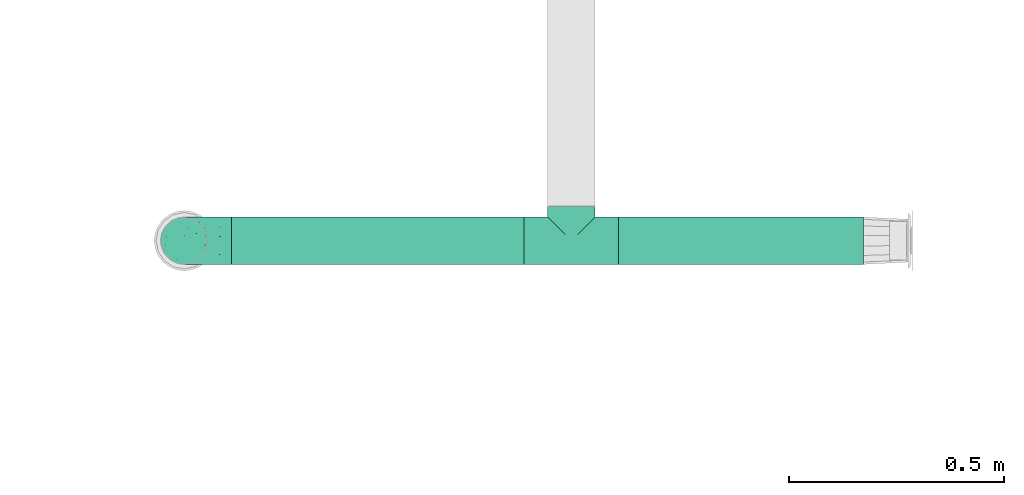
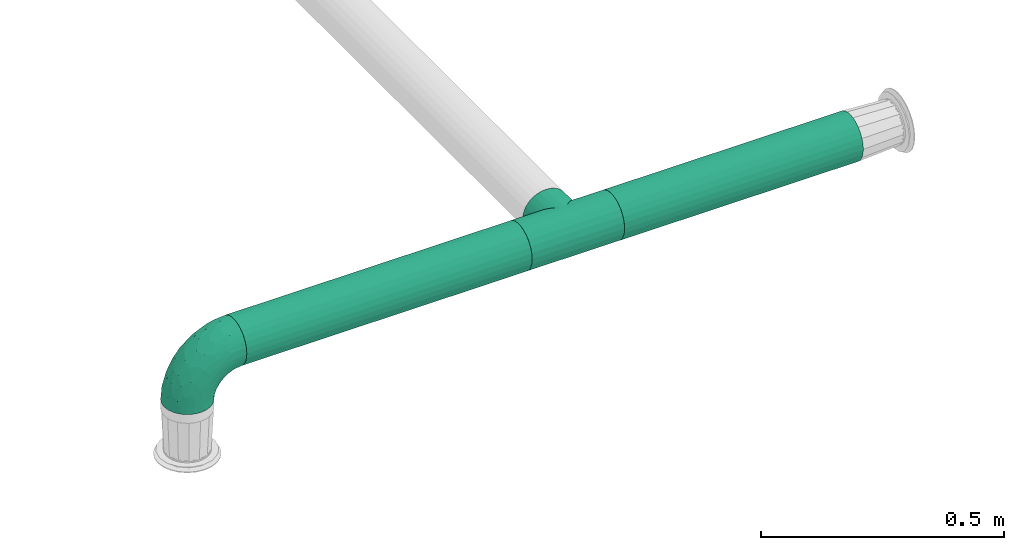
# One storey, part 101 of 123: 2 flow fittings, 2 flow segments.
"""IFC2X3 building model written with IfcOpenShell, lengths in millimetres."""

from ifc_helpers import new_model, entity, si_unit, converted_unit, derived_unit, direction, frame, origin_with_axes, origin_2d_with_axis, place, context, subcontext, project, spatial, hollow_circle, extrude, open_shell, surface_model, source, transform, mapped, material, layer, layer_set, layer_usage, type_object, element, save


model = new_model("IFC2X3")

# Units and contexts
model_context = context("Model", 3, precision=1e-05, world=origin_with_axes(), true_north=direction((0.0, 1.0)))
body_context = subcontext(model_context, "Body", "Model", "MODEL_VIEW")
ifc_project = project(units=[si_unit("AREAUNIT", "SQUARE_METRE"), si_unit("VOLUMEUNIT", "CUBIC_METRE", prefix="DECI"), si_unit("TIMEUNIT", "SECOND"), si_unit("THERMODYNAMICTEMPERATUREUNIT", "DEGREE_CELSIUS"), si_unit("PRESSUREUNIT", "PASCAL"), si_unit("MASSUNIT", "GRAM", prefix="KILO"), si_unit("LENGTHUNIT", "METRE", prefix="MILLI"), si_unit("POWERUNIT", "WATT"), si_unit("ELECTRICCURRENTUNIT", "AMPERE"), si_unit("ELECTRICVOLTAGEUNIT", "VOLT"), derived_unit("VOLUMETRICFLOWRATEUNIT", [(si_unit("VOLUMEUNIT", "CUBIC_METRE", prefix="DECI"), 1), (si_unit("TIMEUNIT", "SECOND"), -1)]), derived_unit("LINEARVELOCITYUNIT", [(si_unit("LENGTHUNIT", "METRE"), 1), (si_unit("TIMEUNIT", "SECOND"), -1)]), derived_unit("MASSDENSITYUNIT", [(si_unit("MASSUNIT", "GRAM", prefix="KILO"), 1), (si_unit("VOLUMEUNIT", "CUBIC_METRE"), -1)]), converted_unit("PLANEANGLEUNIT", "DEGREE", entity("IfcRatioMeasure", 0.01745), si_unit("PLANEANGLEUNIT", "RADIAN"), dimensions=[0, 0, 0, 0, 0, 0, 0])], contexts=[model_context])

# Site, building, storey
site_placement = place(None, origin_with_axes())
site = spatial("IfcSite", under=ifc_project, at=site_placement, CompositionType="ELEMENT")
building_placement = place(site_placement, origin_with_axes())
building = spatial("IfcBuilding", under=site, at=building_placement, Name="mc-building", CompositionType="ELEMENT")
storey_placement = place(building_placement, origin_with_axes())
storey = spatial("IfcBuildingStorey", under=building, at=storey_placement, Name="1. Korrus", CompositionType="ELEMENT", Elevation=0.0)

# Flow fitting
duct_fitting_type_1 = type_object("IfcDuctFittingType", PredefinedType="JUNCTION")
shared_shape_1 = source(origin_with_axes(), body_context, "Body", "SurfaceModel", [
    surface_model("IfcShellBasedSurfaceModel", [(0.0, -80.0, -55.0), (14.23505, -80.0, -53.12592), (-14.23505, -80.0, -53.12592), (-53.12592, -80.0, 14.23505), (-27.5, -80.0, -47.63139), (-47.63139, -80.0, -27.5), (-38.89087, -80.0, -38.89087), (55.0, -80.0, 0.0), (53.12592, -80.0, 14.23505), (38.89087, -80.0, -38.89087), (27.5, -80.0, -47.63139), (53.12592, -80.0, -14.23505), (47.63139, -80.0, -27.5), (-53.12592, -80.0, -14.23505), (-47.63139, -80.0, 27.5), (-38.89087, -80.0, 38.89087), (14.23505, -80.0, 53.12592), (-27.5, -80.0, 47.63139), (-14.23505, -80.0, 53.12592), (47.63139, -80.0, 27.5), (38.89087, -80.0, 38.89087), (27.5, -80.0, 47.63139), (0.0, -80.0, 55.0), (-55.0, -80.0, 0.0), (0.0, 0.0, 55.0), (-7.4066, -7.4066, 54.49901), (-14.74521, -14.74521, 52.98659), (-21.93978, -21.93978, 50.43457), (-28.89905, -28.89905, 46.79578), (-35.50357, -35.50357, 42.00591), (-41.58668, -41.58668, 35.99373), (-46.92319, -46.92319, 28.69171), (-51.19777, -51.19777, 20.0945), (-50.37866, -80.0, 20.86752), (-54.01174, -54.01174, 10.37938), (-55.0, -55.0, 0.0), (-54.06296, -80.0, 7.11752), (-54.01174, -54.01174, -10.37938), (-51.19777, -51.19777, -20.0945), (-54.06296, -80.0, -7.11752), (-46.92319, -46.92319, -28.69171), (-41.58668, -41.58668, -35.99373), (-50.37866, -80.0, -20.86752), (-35.50357, -35.50357, -42.00591), (-21.93978, -21.93978, -50.43457), (-14.74521, -14.74521, -52.98659), (-7.4066, -7.4066, -54.49901), (0.0, 0.0, -55.0), (-28.89905, -28.89905, -46.79578), (7.4066, -7.4066, -54.49901), (14.74521, -14.74521, -52.98659), (21.93978, -21.93978, -50.43457), (28.89905, -28.89905, -46.79578), (35.50357, -35.50357, -42.00591), (41.58668, -41.58668, -35.99373), (46.92319, -46.92319, -28.69171), (51.19777, -51.19777, -20.0945), (50.37866, -80.0, -20.86752), (54.01174, -54.01174, -10.37938), (55.0, -55.0, 0.0), (54.06296, -80.0, -7.11752), (54.01174, -54.01174, 10.37938), (51.19777, -51.19777, 20.0945), (54.06296, -80.0, 7.11752), (46.92319, -46.92319, 28.69171), (41.58668, -41.58668, 35.99373), (50.37866, -80.0, 20.86752), (35.50357, -35.50357, 42.00591), (21.93978, -21.93978, 50.43457), (14.74521, -14.74521, 52.98659), (7.4066, -7.4066, 54.49901), (28.89905, -28.89905, 46.79578), (-110.0, 0.0, -55.0), (-110.0, -14.23505, -53.12592), (-110.0, 14.23505, -53.12592), (-110.0, 53.12592, 14.23505), (-110.0, 27.5, -47.63139), (-110.0, 47.63139, -27.5), (-110.0, 38.89087, -38.89087), (-110.0, -55.0, 0.0), (-110.0, -53.12592, 14.23505), (-110.0, -38.89087, -38.89087), (-110.0, -27.5, -47.63139), (-110.0, -53.12592, -14.23505), (-110.0, -47.63139, -27.5), (-110.0, 53.12592, -14.23505), (-110.0, 47.63139, 27.5), (-110.0, 38.89087, 38.89087), (-110.0, -14.23505, 53.12592), (-110.0, 27.5, 47.63139), (-110.0, 14.23505, 53.12592), (-110.0, -47.63139, 27.5), (-110.0, -38.89087, 38.89087), (-110.0, -27.5, 47.63139), (-110.0, 0.0, 55.0), (-110.0, 55.0, 0.0), (110.0, 55.0, 0.0), (110.0, 0.0, -55.0), (110.0, 14.23505, -53.12592), (110.0, 27.5, -47.63139), (110.0, 38.89087, -38.89087), (110.0, 47.63139, -27.5), (110.0, -38.89087, -38.89087), (110.0, -53.12592, 14.23505), (110.0, -27.5, -47.63139), (110.0, -14.23505, -53.12592), (110.0, -47.63139, -27.5), (110.0, -53.12592, -14.23505), (110.0, -55.0, 0.0), (110.0, 53.12592, -14.23505), (110.0, 53.12592, 14.23505), (110.0, 47.63139, 27.5), (110.0, 38.89087, 38.89087), (110.0, 0.0, 55.0), (110.0, 27.5, 47.63139), (110.0, 14.23505, 53.12592), (110.0, -47.63139, 27.5), (110.0, -38.89087, 38.89087), (110.0, -27.5, 47.63139), (110.0, -14.23505, 53.12592)], [open_shell([[[0, 1, 2]], [[2, 3, 4]], [[5, 6, 3]], [[6, 4, 3]], [[2, 7, 8]], [[9, 7, 10]], [[1, 10, 7]], [[11, 7, 12]], [[9, 12, 7]], [[7, 2, 1]], [[5, 3, 13]], [[2, 14, 3]], [[2, 15, 14]], [[2, 16, 17]], [[17, 15, 2]], [[16, 18, 17]], [[2, 8, 19]], [[2, 19, 20]], [[2, 20, 21]], [[16, 2, 21]], [[16, 22, 18]], [[23, 13, 3]], [[24, 25, 22]], [[26, 27, 18]], [[25, 26, 18]], [[22, 25, 18]], [[17, 28, 29]], [[17, 18, 27]], [[17, 29, 15]], [[28, 17, 27]], [[30, 31, 14]], [[32, 3, 33]], [[32, 34, 3]], [[35, 36, 34]], [[31, 32, 14]], [[15, 30, 14]], [[34, 36, 3]], [[33, 14, 32]], [[36, 35, 23]], [[30, 15, 29]], [[37, 38, 13]], [[37, 13, 39]], [[40, 41, 5]], [[38, 5, 42]], [[38, 40, 5]], [[37, 39, 35]], [[35, 39, 23]], [[13, 38, 42]], [[41, 6, 5]], [[41, 43, 6]], [[44, 45, 2]], [[46, 47, 0]], [[45, 46, 2]], [[43, 48, 4]], [[44, 4, 48]], [[44, 2, 4]], [[46, 0, 2]], [[43, 4, 6]], [[47, 49, 0]], [[50, 51, 1]], [[49, 50, 1]], [[0, 49, 1]], [[10, 52, 53]], [[10, 1, 51]], [[10, 53, 9]], [[52, 10, 51]], [[54, 55, 12]], [[56, 11, 57]], [[56, 58, 11]], [[59, 60, 58]], [[55, 56, 12]], [[9, 54, 12]], [[58, 60, 11]], [[57, 12, 56]], [[60, 59, 7]], [[54, 9, 53]], [[61, 62, 8]], [[61, 8, 63]], [[64, 65, 19]], [[62, 19, 66]], [[62, 64, 19]], [[61, 63, 59]], [[7, 59, 63]], [[62, 66, 8]], [[65, 20, 19]], [[65, 67, 20]], [[68, 69, 16]], [[70, 24, 22]], [[69, 70, 16]], [[67, 71, 21]], [[68, 21, 71]], [[68, 16, 21]], [[70, 22, 16]], [[67, 21, 20]], [[72, 73, 74]], [[74, 75, 76]], [[77, 78, 75]], [[76, 75, 78]], [[74, 79, 80]], [[81, 79, 82]], [[73, 82, 79]], [[83, 79, 84]], [[81, 84, 79]], [[79, 74, 73]], [[77, 75, 85]], [[74, 86, 75]], [[74, 87, 86]], [[74, 88, 89]], [[89, 87, 74]], [[88, 90, 89]], [[74, 91, 92]], [[91, 74, 80]], [[92, 93, 74]], [[74, 93, 88]], [[88, 94, 90]], [[95, 85, 75]], [[96, 97, 98]], [[99, 96, 98]], [[96, 100, 101]], [[100, 96, 99]], [[102, 97, 103]], [[97, 102, 104]], [[104, 105, 97]], [[102, 103, 106]], [[106, 103, 107]], [[108, 107, 103]], [[109, 96, 101]], [[110, 111, 97]], [[97, 111, 112]], [[113, 97, 114]], [[97, 112, 114]], [[113, 114, 115]], [[116, 103, 97]], [[117, 116, 97]], [[118, 117, 97]], [[119, 118, 97]], [[119, 97, 113]], [[96, 110, 97]], [[24, 113, 115]], [[89, 115, 114]], [[94, 24, 90]], [[90, 24, 115]], [[115, 89, 90]], [[114, 87, 89]], [[86, 112, 111]], [[75, 111, 110]], [[95, 110, 96]], [[87, 112, 86]], [[86, 111, 75]], [[110, 95, 75]], [[112, 87, 114]], [[85, 96, 109]], [[77, 109, 101]], [[95, 96, 85]], [[85, 109, 77]], [[101, 78, 77]], [[101, 100, 78]], [[76, 100, 99]], [[74, 99, 98]], [[47, 98, 97]], [[76, 99, 74]], [[47, 72, 74]], [[98, 47, 74]], [[100, 76, 78]], [[47, 46, 72]], [[45, 44, 73]], [[46, 45, 73]], [[72, 46, 73]], [[82, 48, 43]], [[82, 73, 44]], [[82, 43, 81]], [[48, 82, 44]], [[41, 40, 84]], [[38, 37, 83]], [[40, 38, 84]], [[81, 41, 84]], [[37, 79, 83]], [[83, 84, 38]], [[79, 37, 35]], [[41, 81, 43]], [[49, 97, 105]], [[105, 104, 51]], [[53, 104, 102]], [[53, 52, 104]], [[49, 47, 97]], [[51, 50, 105]], [[52, 51, 104]], [[49, 105, 50]], [[54, 102, 106]], [[56, 106, 107]], [[58, 107, 108]], [[55, 54, 106]], [[58, 56, 107]], [[59, 58, 108]], [[55, 106, 56]], [[102, 54, 53]], [[34, 32, 80]], [[31, 30, 91]], [[32, 31, 91]], [[35, 34, 79]], [[80, 79, 34]], [[32, 91, 80]], [[30, 92, 91]], [[30, 29, 92]], [[27, 26, 88]], [[25, 24, 94]], [[26, 25, 88]], [[29, 28, 93]], [[27, 93, 28]], [[27, 88, 93]], [[25, 94, 88]], [[29, 93, 92]], [[61, 108, 103]], [[62, 103, 116]], [[65, 116, 117]], [[61, 59, 108]], [[64, 62, 116]], [[65, 64, 116]], [[61, 103, 62]], [[117, 67, 65]], [[71, 67, 118]], [[118, 67, 117]], [[68, 118, 119]], [[70, 119, 113]], [[68, 71, 118]], [[70, 69, 119]], [[24, 70, 113]], [[68, 119, 69]]])]),
])
flow_fitting_1_placement = place(storey_placement, frame((33028.54629, 9877.62755, 2435.0), z_axis=(0.0, 0.0, 1.0), x_axis=(-1.0, 0.0, 0.0)))
element("IfcFlowFitting", 1, at=flow_fitting_1_placement, inside=storey, type_object=duct_fitting_type_1, context=body_context, shape_type="MappedRepresentation", body=[
    mapped(shared_shape_1, transform((0.0, 0.0, 0.0), scale=1.0)),
])

# Flow segment
ifc_material = material(Name="FZ1")
ifc_layer = layer(ifc_material, 0.0)
ifc_layer_set = layer_set([ifc_layer], Name="FZ1")
ifc_layer_usage = layer_usage(ifc_layer_set, "AXIS1", "POSITIVE", 0.0)
duct_segment_type = type_object("IfcDuctSegmentType", PredefinedType="RIGIDSEGMENT")
shared_shape_2 = source(origin_with_axes(), body_context, "Body", "SweptSolid", [
    extrude(hollow_circle(Radius=55.0, WallThickness=2.0, at=origin_2d_with_axis()), frame((0.0, 0.0, 0.0), z_axis=(1.0, 0.0, 0.0), x_axis=(0.0, 1.0, 0.0)), (0.0, 0.0, 1.0), 568.2),
])
flow_segment_1_placement = place(storey_placement, frame((33138.54629, 9877.62755, 2435.0), z_axis=(0.0, 0.0, 1.0), x_axis=(1.0, 0.0, 0.0)))
element("IfcFlowSegment", 2, at=flow_segment_1_placement, inside=storey, type_object=duct_segment_type, material=ifc_layer_usage, context=body_context, shape_type="MappedRepresentation", body=[
    mapped(shared_shape_2, transform((0.0, 0.0, 0.0), scale=1.0)),
])

# Flow fitting
duct_fitting_type_2 = type_object("IfcDuctFittingType", Name="BU", PredefinedType="BEND")
shared_shape_3 = source(origin_with_axes(), body_context, "Body", "SurfaceModel", [
    surface_model("IfcShellBasedSurfaceModel", [(-110.0, 0.0, -55.0), (-110.0, -14.23505, -53.12592), (-110.0, 14.23505, -53.12592), (-110.0, 53.12592, 14.23505), (-110.0, 27.5, -47.63139), (-110.0, 38.89087, -38.89087), (-110.0, -55.0, 0.0), (-110.0, -53.12592, 14.23505), (-110.0, -38.89087, -38.89087), (-110.0, -27.5, -47.63139), (-110.0, -53.12592, -14.23505), (-110.0, -47.63139, -27.5), (-110.0, -14.23505, 53.12592), (-110.0, 14.23505, 53.12592), (-110.0, 27.5, 47.63139), (-110.0, -47.63139, 27.5), (-110.0, -38.89087, 38.89087), (-110.0, -27.5, 47.63139), (-110.0, 0.0, 55.0), (-110.0, 55.0, 0.0), (-110.0, 53.12592, -14.23505), (-110.0, 47.63139, -27.5), (-110.0, 47.63139, 27.5), (-110.0, 38.89087, 38.89087), (-14.23505, 110.0, -53.12592), (-55.0, 110.0, 0.0), (0.0, 110.0, -55.0), (-27.5, 110.0, -47.63139), (-38.89087, 110.0, -38.89087), (-47.63139, 110.0, -27.5), (38.89087, 110.0, -38.89087), (53.12592, 110.0, 14.23505), (27.5, 110.0, -47.63139), (14.23505, 110.0, -53.12592), (47.63139, 110.0, -27.5), (53.12592, 110.0, -14.23505), (55.0, 110.0, 0.0), (-53.12592, 110.0, -14.23505), (-53.12592, 110.0, 14.23505), (-47.63139, 110.0, 27.5), (-38.89087, 110.0, 38.89087), (-27.5, 110.0, 47.63139), (0.0, 110.0, 55.0), (-14.23505, 110.0, 53.12592), (38.89087, 110.0, 38.89087), (47.63139, 110.0, 27.5), (27.5, 110.0, 47.63139), (14.23505, 110.0, 53.12592), (-64.21732, 48.68956, 43.63444), (-76.6405, 38.18013, 45.55988), (-60.44912, 32.56953, 51.94617), (-76.00813, 5.38378, 55.0), (-90.15553, 11.94394, 54.09138), (-78.5998, 26.77405, 50.81338), (-70.18771, 18.55163, 54.03432), (-75.55424, 54.2118, 32.41257), (-93.27622, 45.77614, 33.48188), (-96.12334, 22.13664, 50.81337), (-21.00813, 45.34362, 55.0), (-18.36258, 70.48427, 54.04484), (-32.04182, 59.64019, 52.24446), (-63.88653, 74.77858, 17.99134), (-74.66383, 63.08407, 19.92123), (-63.60674, 66.07878, 29.97482), (-99.597, 52.72185, 18.52927), (-93.11138, 56.59448, 10.50359), (-98.21577, 57.34403, 0.0), (-53.42855, 92.60092, 21.04759), (-88.54852, 54.8376, 21.04759), (-11.86161, 90.23965, 54.10313), (-5.38378, 76.00813, 55.0), (-57.34403, 98.21577, 0.0), (-56.64619, 93.12774, 10.22088), (-45.34362, 21.00813, 55.0), (-44.60838, 44.60838, 52.13415), (-92.68484, 35.46673, 43.63443), (-22.25266, 95.40765, 50.81337), (-35.97783, 90.61597, 43.63443), (-43.70931, 69.58671, 44.47149), (-27.23711, 77.39884, 50.81337), (-57.2828, 79.3123, 24.9774), (-58.67786, 84.31125, 16.04456), (-82.93277, 60.36161, 12.91784), (-49.88337, 54.51816, 47.224), (-74.57753, 66.83759, 9.55742), (-45.35812, 94.97281, 33.48188), (-59.18663, 88.95241, 0.0), (-51.517, 78.6292, 33.48188), (-65.14788, 80.03077, 0.0), (-56.45322, 62.06476, 39.63545), (-88.95241, 59.18663, 0.0), (-71.10913, 71.10913, 0.0), (-80.03077, 65.14788, 0.0), (-94.9309, 45.36788, -33.48188), (-93.11358, 56.60141, -10.46614), (-99.64997, 52.79499, -18.30015), (-90.20425, 36.08686, -43.63443), (-79.99933, 46.56772, -37.92748), (-76.00813, 5.38378, -55.0), (-72.75364, 19.68651, -53.60527), (-45.34362, 21.00813, -55.0), (-21.91957, 65.12078, -53.85897), (-5.38378, 76.00813, -55.0), (-21.00813, 45.34362, -55.0), (-35.41876, 92.89265, -43.63443), (-91.10309, 11.02766, -54.21832), (-45.77614, 93.27622, -33.48188), (-90.50474, 23.21022, -50.81337), (-70.92854, 33.31794, -49.51754), (-78.52933, 63.35627, -11.73997), (-24.91508, 84.05606, -50.81337), (-88.78941, 54.74452, -21.04759), (-69.59921, 57.34866, -33.48187), (-73.36422, 62.46673, -22.94182), (-63.49062, 67.59111, -28.46929), (-56.59448, 93.11138, -10.50359), (-54.8376, 88.54852, -21.04759), (-54.10679, 75.85581, -32.31867), (-57.75956, 31.09612, -52.80882), (-52.72185, 99.597, -18.52927), (-12.62913, 89.46304, -53.99097), (-34.46825, 66.46123, -50.04329), (-43.9837, 43.9837, -52.42279), (-65.78527, 72.58348, -17.68796), (-70.34468, 43.65295, -44.21951), (-57.47001, 51.99467, -44.91465), (-60.72547, 82.29174, -12.88567), (-42.34915, 74.24548, -43.63444), (-57.25194, 63.5016, -38.08211), (-80.95344, 53.56991, -29.32027), (-52.32891, 4.55257, -54.0482), (32.52942, 47.13398, -30.48571), (14.88266, 20.92917, -33.7947), (14.95561, 36.05775, -42.26543), (30.24048, 70.09027, -41.7461), (19.3559, 65.35825, -48.00507), (-70.35075, -46.44478, -19.5952), (-47.13398, -32.52942, -30.48571), (-28.49299, -30.5778, -16.4009), (-4.55257, 52.32891, -54.0482), (-22.4954, 22.4954, -53.25347), (-75.47368, -11.22546, -52.60718), (-81.32209, -51.5606, -9.98467), (-80.81763, -41.84862, -32.14655), (-70.09027, -30.24048, -41.7461), (-36.05774, -14.95561, -42.26543), (-9.15831, -10.852, -27.8997), (-65.35825, -19.3559, -48.00507), (11.22546, 75.47368, -52.60718), (3.94376, 43.9333, -50.53315), (-13.39742, 13.39743, -48.13058), (-43.9333, -3.94376, -50.53315), (49.37776, 67.29486, 0.0), (41.8609, 47.82256, -9.92641), (50.20582, 74.51695, -9.9731), (18.93131, 11.7156, -17.56239), (-27.5, -32.89419, 0.0), (-1.23348, -12.25375, -12.18106), (41.84862, 80.81763, -32.14655), (35.70604, 41.31408, -20.38235), (46.44478, 70.35075, -19.5952), (32.89419, 27.5, 0.0), (6.67262, -6.67262, 0.0), (-67.29486, -49.37776, 0.0), (-50.36265, -42.95545, -9.51562), (-5.47251, 5.47251, -39.92906), (-70.35075, -46.44478, 19.5952), (-74.51695, -50.20582, 9.9731), (-41.31407, -35.70604, 20.38235), (-47.13398, -32.52942, 30.48571), (-80.81763, -41.84862, 32.14655), (-4.55257, 52.32891, 54.0482), (11.22546, 75.47368, 52.60718), (-43.9333, -3.94376, 50.53315), (-65.35825, -19.3559, 48.00507), (-36.05774, -14.95561, 42.26543), (-70.09027, -30.24048, 41.7461), (-11.7156, -18.93131, 17.56239), (30.5778, 28.49299, 16.4009), (12.25375, 1.23348, 12.18106), (51.5606, 81.32209, 9.98467), (42.95545, 50.36265, 9.51562), (-75.47368, -11.22546, 52.60718), (-52.32891, 4.55257, 54.0482), (3.94376, 43.9333, 50.53315), (-22.4954, 22.4954, 53.25347), (-13.39742, 13.39743, 48.13058), (10.852, 9.15831, 27.8997), (-20.92916, -14.88266, 33.79469), (-47.82256, -41.8609, 9.92641), (32.52942, 47.13398, 30.48571), (46.44478, 70.35075, 19.5952), (41.84862, 80.81763, 32.14655), (30.24048, 70.09027, 41.7461), (19.3559, 65.35825, 48.00507), (14.95561, 36.05775, 42.26543), (-5.47251, 5.47251, 39.92906)], [open_shell([[[0, 1, 2]], [[2, 3, 4]], [[4, 3, 5]], [[2, 6, 7]], [[8, 6, 9]], [[1, 9, 6]], [[10, 6, 11]], [[8, 11, 6]], [[6, 2, 1]], [[12, 13, 14]], [[15, 2, 7]], [[16, 17, 2]], [[2, 17, 12]], [[12, 18, 13]], [[19, 20, 3]], [[5, 3, 21]], [[20, 21, 3]], [[22, 3, 2]], [[23, 22, 2]], [[12, 14, 2]], [[2, 14, 23]], [[15, 16, 2]], [[24, 25, 26]], [[27, 25, 24]], [[25, 28, 29]], [[28, 25, 27]], [[30, 26, 31]], [[26, 30, 32]], [[32, 33, 26]], [[34, 31, 35]], [[31, 34, 30]], [[35, 31, 36]], [[29, 37, 25]], [[38, 39, 26]], [[39, 40, 26]], [[41, 42, 40]], [[42, 26, 40]], [[42, 41, 43]], [[26, 44, 45]], [[31, 26, 45]], [[26, 46, 44]], [[47, 46, 26]], [[42, 47, 26]], [[25, 38, 26]], [[48, 49, 50]], [[18, 51, 52]], [[53, 54, 50]], [[55, 56, 49]], [[56, 22, 23]], [[13, 57, 14]], [[58, 59, 60]], [[61, 62, 63]], [[3, 64, 65]], [[53, 52, 54]], [[3, 65, 66]], [[67, 39, 38]], [[56, 68, 64]], [[65, 64, 68]], [[69, 59, 70]], [[38, 71, 72]], [[73, 58, 74]], [[75, 49, 56]], [[76, 69, 43]], [[53, 57, 52]], [[77, 78, 79]], [[41, 76, 43]], [[43, 69, 42]], [[55, 68, 56]], [[23, 14, 75]], [[76, 77, 79]], [[80, 67, 81]], [[62, 82, 68]], [[60, 78, 83]], [[62, 84, 82]], [[85, 77, 40]], [[81, 67, 72]], [[86, 72, 71]], [[87, 85, 67]], [[61, 81, 88]], [[77, 41, 40]], [[78, 77, 87]], [[23, 75, 56]], [[83, 89, 48]], [[85, 40, 39]], [[62, 68, 55]], [[89, 87, 63]], [[83, 48, 50]], [[57, 75, 14]], [[49, 75, 53]], [[67, 85, 39]], [[87, 77, 85]], [[63, 62, 55]], [[89, 55, 48]], [[80, 63, 87]], [[66, 65, 90]], [[66, 19, 3]], [[84, 91, 92]], [[92, 90, 82]], [[65, 82, 90]], [[61, 84, 62]], [[92, 82, 84]], [[68, 82, 65]], [[3, 22, 64]], [[56, 64, 22]], [[38, 25, 71]], [[81, 72, 86]], [[38, 72, 67]], [[91, 61, 88]], [[80, 81, 61]], [[63, 80, 61]], [[67, 80, 87]], [[77, 76, 41]], [[79, 59, 69]], [[79, 69, 76]], [[42, 69, 70]], [[60, 59, 79]], [[58, 70, 59]], [[78, 60, 79]], [[58, 60, 74]], [[52, 57, 13]], [[75, 57, 53]], [[18, 52, 13]], [[52, 51, 54]], [[51, 73, 54]], [[50, 73, 74]], [[73, 50, 54]], [[50, 74, 83]], [[60, 83, 74]], [[89, 83, 78]], [[87, 89, 78]], [[55, 89, 63]], [[50, 49, 53]], [[55, 49, 48]], [[81, 86, 88]], [[91, 84, 61]], [[5, 21, 93]], [[90, 94, 66]], [[20, 94, 95]], [[96, 93, 97]], [[98, 99, 100]], [[96, 4, 5]], [[101, 102, 103]], [[28, 27, 104]], [[2, 105, 0]], [[104, 106, 28]], [[99, 105, 107]], [[108, 107, 96]], [[90, 109, 94]], [[107, 2, 4]], [[20, 66, 94]], [[27, 24, 110]], [[109, 111, 94]], [[112, 113, 114]], [[37, 115, 71]], [[116, 106, 117]], [[99, 118, 100]], [[116, 115, 119]], [[37, 119, 115]], [[24, 120, 110]], [[121, 110, 101]], [[119, 106, 116]], [[101, 110, 120]], [[122, 103, 100]], [[117, 123, 116]], [[124, 125, 108]], [[115, 116, 126]], [[106, 29, 28]], [[26, 102, 120]], [[127, 104, 110]], [[97, 124, 96]], [[125, 122, 118]], [[128, 127, 125]], [[96, 5, 93]], [[115, 126, 86]], [[117, 106, 127]], [[111, 113, 129]], [[95, 93, 21]], [[97, 129, 112]], [[110, 104, 27]], [[106, 104, 127]], [[96, 107, 4]], [[99, 107, 108]], [[99, 108, 118]], [[105, 99, 98]], [[112, 114, 128]], [[121, 125, 127]], [[20, 19, 66]], [[109, 90, 92]], [[94, 111, 95]], [[91, 123, 109]], [[129, 113, 112]], [[93, 95, 111]], [[21, 20, 95]], [[71, 115, 86]], [[71, 25, 37]], [[123, 91, 88]], [[126, 116, 123]], [[123, 88, 126]], [[86, 126, 88]], [[37, 29, 119]], [[106, 119, 29]], [[129, 93, 111]], [[124, 112, 125]], [[0, 105, 98]], [[107, 105, 2]], [[125, 118, 108]], [[100, 118, 122]], [[93, 129, 97]], [[113, 111, 109]], [[109, 123, 113]], [[114, 123, 117]], [[123, 114, 113]], [[128, 114, 117]], [[127, 128, 117]], [[112, 128, 125]], [[103, 122, 101]], [[110, 121, 127]], [[101, 122, 121]], [[125, 121, 122]], [[26, 120, 24]], [[101, 120, 102]], [[96, 124, 108]], [[92, 91, 109]], [[112, 124, 97]], [[100, 130, 98]], [[131, 132, 133]], [[32, 134, 135]], [[136, 137, 138]], [[139, 140, 103]], [[98, 141, 0]], [[142, 10, 136]], [[143, 144, 137]], [[6, 10, 142]], [[137, 145, 146]], [[144, 147, 145]], [[143, 136, 11]], [[11, 136, 10]], [[8, 143, 11]], [[148, 149, 139]], [[8, 9, 144]], [[9, 1, 147]], [[130, 141, 98]], [[103, 140, 100]], [[148, 135, 149]], [[150, 151, 140]], [[152, 153, 154]], [[130, 140, 151]], [[148, 26, 33]], [[147, 1, 141]], [[155, 146, 132]], [[156, 138, 157]], [[134, 30, 158]], [[150, 140, 149]], [[158, 30, 34]], [[30, 134, 32]], [[153, 159, 160]], [[131, 160, 159]], [[144, 145, 137]], [[36, 152, 154]], [[146, 138, 137]], [[155, 161, 162]], [[158, 160, 131]], [[133, 149, 135]], [[156, 163, 164]], [[163, 142, 164]], [[139, 103, 102]], [[153, 152, 161]], [[34, 35, 160]], [[162, 157, 155]], [[132, 165, 133]], [[157, 146, 155]], [[140, 130, 100]], [[141, 130, 151]], [[141, 151, 147]], [[141, 1, 0]], [[102, 26, 148]], [[140, 139, 149]], [[102, 148, 139]], [[135, 33, 32]], [[151, 150, 145]], [[9, 147, 144]], [[151, 145, 147]], [[145, 165, 146]], [[135, 148, 33]], [[133, 135, 134]], [[131, 133, 134]], [[133, 165, 150]], [[133, 150, 149]], [[145, 150, 165]], [[132, 131, 159]], [[146, 165, 132]], [[160, 158, 34]], [[134, 158, 131]], [[144, 143, 8]], [[136, 143, 137]], [[155, 153, 161]], [[154, 153, 160]], [[153, 155, 159]], [[132, 159, 155]], [[160, 35, 154]], [[36, 154, 35]], [[164, 136, 138]], [[6, 142, 163]], [[136, 164, 142]], [[156, 164, 138]], [[156, 157, 162]], [[146, 157, 138]], [[15, 7, 166]], [[6, 163, 167]], [[168, 169, 166]], [[166, 169, 170]], [[171, 172, 70]], [[173, 174, 175]], [[17, 176, 174]], [[177, 156, 162]], [[176, 16, 170]], [[170, 16, 15]], [[161, 178, 179]], [[152, 180, 181]], [[182, 173, 183]], [[18, 12, 182]], [[184, 185, 186]], [[183, 185, 73]], [[183, 73, 51]], [[177, 187, 188]], [[189, 168, 166]], [[187, 178, 190]], [[16, 176, 17]], [[161, 152, 181]], [[45, 191, 31]], [[45, 44, 192]], [[192, 191, 45]], [[180, 36, 31]], [[193, 194, 195]], [[46, 47, 194]], [[193, 195, 190]], [[193, 44, 46]], [[172, 42, 70]], [[185, 58, 73]], [[189, 163, 156]], [[163, 189, 167]], [[70, 58, 171]], [[184, 171, 185]], [[169, 188, 175]], [[180, 31, 191]], [[192, 193, 190]], [[191, 190, 178]], [[182, 174, 173]], [[194, 47, 172]], [[190, 195, 187]], [[186, 185, 173]], [[162, 179, 177]], [[188, 196, 175]], [[179, 187, 177]], [[185, 171, 58]], [[172, 171, 184]], [[172, 184, 194]], [[172, 47, 42]], [[51, 18, 182]], [[185, 183, 173]], [[51, 182, 183]], [[174, 12, 17]], [[184, 186, 195]], [[46, 194, 193]], [[184, 195, 194]], [[195, 196, 187]], [[174, 182, 12]], [[175, 174, 176]], [[169, 175, 176]], [[175, 196, 186]], [[175, 186, 173]], [[195, 186, 196]], [[188, 169, 168]], [[187, 196, 188]], [[166, 170, 15]], [[176, 170, 169]], [[193, 192, 44]], [[191, 192, 190]], [[177, 189, 156]], [[167, 189, 166]], [[189, 177, 168]], [[188, 168, 177]], [[166, 7, 167]], [[6, 167, 7]], [[181, 191, 178]], [[36, 180, 152]], [[191, 181, 180]], [[161, 181, 178]], [[161, 179, 162]], [[187, 179, 178]]])]),
])
flow_fitting_2_placement = place(storey_placement, frame((32129.61982, 9877.62755, 2435.0), z_axis=(0.0, 1.0, 0.0), x_axis=(0.0, 0.0, 1.0)))
element("IfcFlowFitting", 3, at=flow_fitting_2_placement, inside=storey, type_object=duct_fitting_type_2, Name="BU", context=body_context, shape_type="MappedRepresentation", body=[
    mapped(shared_shape_3, transform((0.0, 0.0, 0.0), scale=1.0)),
])

# Flow segment
shared_shape_4 = source(origin_with_axes(), body_context, "Body", "SweptSolid", [
    extrude(hollow_circle(Radius=55.0, WallThickness=2.0, at=origin_2d_with_axis()), frame((0.0, 0.0, 0.0), z_axis=(1.0, 0.0, 0.0), x_axis=(0.0, 1.0, 0.0)), (0.0, 0.0, 1.0), 678.9),
])
flow_segment_2_placement = place(storey_placement, frame((32239.61982, 9877.62755, 2435.0), z_axis=(0.0, 0.0, 1.0), x_axis=(1.0, 0.0, 0.0)))
element("IfcFlowSegment", 4, at=flow_segment_2_placement, inside=storey, type_object=duct_segment_type, material=ifc_layer_usage, context=body_context, shape_type="MappedRepresentation", body=[
    mapped(shared_shape_4, transform((0.0, 0.0, 0.0), scale=1.0)),
])

save(model, "model.ifc")
